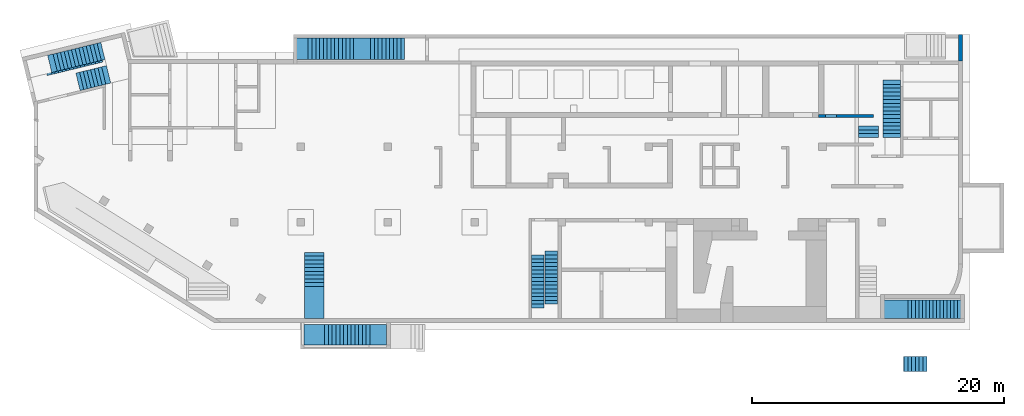
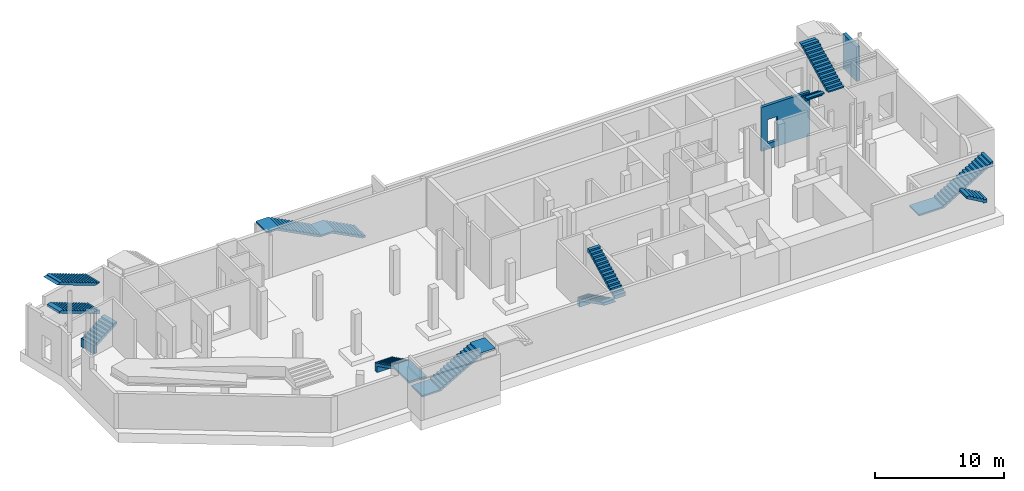
# One storey, part 4 of 9: 11 stairs, 2 walls, 2 openings.
"""IFC4 building model written with IfcOpenShell, lengths in millimetres."""

from ifc_helpers import new_model, entity, si_unit, converted_unit, derived_unit, direction, frame, origin, place, context, subcontext, project, spatial, indexed_curve, outline, extrude, polygons, material, type_object, element, save


model = new_model("IFC4")

# Units and contexts
model_context = context("Model", 3, precision=0.01, world=origin(), true_north=direction((6.12303176911189e-17, 1.0)))
plan_context = context("Plan", 3, precision=0.01, world=origin(), true_north=direction((6.12303176911189e-17, 1.0)))
body_context = subcontext(model_context, "Body", "Model", "MODEL_VIEW")
ifc_project = project(units=[si_unit("LENGTHUNIT", "METRE", prefix="MILLI"), si_unit("AREAUNIT", "SQUARE_METRE"), si_unit("VOLUMEUNIT", "CUBIC_METRE"), converted_unit("PLANEANGLEUNIT", "DEGREE", entity("IfcRatioMeasure", 0.0174532925199433), si_unit("PLANEANGLEUNIT", "RADIAN"), dimensions=[0, 0, 0, 0, 0, 0, 0]), si_unit("MASSUNIT", "GRAM", prefix="KILO"), derived_unit("MASSDENSITYUNIT", [(si_unit("MASSUNIT", "GRAM", prefix="KILO"), 1), (si_unit("LENGTHUNIT", "METRE"), -3)]), derived_unit("MOMENTOFINERTIAUNIT", [(si_unit("LENGTHUNIT", "METRE"), 4)]), si_unit("TIMEUNIT", "SECOND"), si_unit("FREQUENCYUNIT", "HERTZ"), si_unit("THERMODYNAMICTEMPERATUREUNIT", "DEGREE_CELSIUS"), derived_unit("THERMALTRANSMITTANCEUNIT", [(si_unit("MASSUNIT", "GRAM", prefix="KILO"), 1), (si_unit("THERMODYNAMICTEMPERATUREUNIT", "KELVIN"), -1), (si_unit("TIMEUNIT", "SECOND"), -3)]), derived_unit("VOLUMETRICFLOWRATEUNIT", [(si_unit("LENGTHUNIT", "METRE"), 3), (si_unit("TIMEUNIT", "SECOND"), -1)]), derived_unit("MASSFLOWRATEUNIT", [(si_unit("MASSUNIT", "GRAM", prefix="KILO"), 1), (si_unit("TIMEUNIT", "SECOND"), -1)]), derived_unit("ROTATIONALFREQUENCYUNIT", [(si_unit("TIMEUNIT", "SECOND"), -1)]), si_unit("ELECTRICCURRENTUNIT", "AMPERE"), si_unit("ELECTRICVOLTAGEUNIT", "VOLT"), si_unit("POWERUNIT", "WATT"), si_unit("FORCEUNIT", "NEWTON", prefix="KILO"), si_unit("ILLUMINANCEUNIT", "LUX"), si_unit("LUMINOUSFLUXUNIT", "LUMEN"), si_unit("LUMINOUSINTENSITYUNIT", "CANDELA"), derived_unit("USERDEFINED", [(si_unit("MASSUNIT", "GRAM", prefix="KILO"), -1), (si_unit("LENGTHUNIT", "METRE"), -2), (si_unit("TIMEUNIT", "SECOND"), 3), (si_unit("LUMINOUSFLUXUNIT", "LUMEN"), 1)]), derived_unit("LINEARVELOCITYUNIT", [(si_unit("LENGTHUNIT", "METRE"), 1), (si_unit("TIMEUNIT", "SECOND"), -1)]), si_unit("PRESSUREUNIT", "PASCAL"), derived_unit("USERDEFINED", [(si_unit("LENGTHUNIT", "METRE"), -2), (si_unit("MASSUNIT", "GRAM", prefix="KILO"), 1), (si_unit("TIMEUNIT", "SECOND"), -2)]), derived_unit("LINEARFORCEUNIT", [(si_unit("MASSUNIT", "GRAM", prefix="KILO"), 1), (si_unit("LENGTHUNIT", "METRE"), 1), (si_unit("TIMEUNIT", "SECOND"), -2), (si_unit("LENGTHUNIT", "METRE"), -1)]), derived_unit("PLANARFORCEUNIT", [(si_unit("MASSUNIT", "GRAM", prefix="KILO"), 1), (si_unit("LENGTHUNIT", "METRE"), 1), (si_unit("TIMEUNIT", "SECOND"), -2), (si_unit("LENGTHUNIT", "METRE"), -2)])], contexts=[model_context, plan_context])

# Site, building, storey
site_placement = place(None, origin())
site = spatial("IfcSite", under=ifc_project, at=site_placement, CompositionType="ELEMENT")
building_placement = place(site_placement, origin())
building = spatial("IfcBuilding", under=site, at=building_placement, CompositionType="ELEMENT")
storey_placement = place(building_placement, frame((0.0, 0.0, -4900.0)))
storey = spatial("IfcBuildingStorey", under=building, at=storey_placement, CompositionType="ELEMENT", Elevation=-4900.0)

# Wall, opening
ifc_material_1 = material()
wall_type_1 = type_object("IfcWallType", PredefinedType="STANDARD")
wall_1_placement = place(storey_placement, frame((73520.0002685547, 20499.999226356, 0.0), z_axis=(0.0, 0.0, 1.0), x_axis=(0.0, 1.0, 0.0)))
wall_1 = element("IfcWall", 1, at=wall_1_placement, inside=storey, type_object=wall_type_1, material=ifc_material_1, PredefinedType="NOTDEFINED", context=body_context, shape_type="Tessellation", body=[
    polygons([(0.0, -150.000000000004, 0.0), (2100.0, -149.999999999999, 0.0), (2100.0, -149.999999999999, 3300.0), (0.000426244457389657, -150.000000000004, 3300.0), (0.0, 149.999999999997, 0.0), (0.0, 149.999999999997, 3300.0), (1800.0, 150.000000000002, 3300.0), (2100.00042624446, 150.000000000002, 3300.0), (2100.0, 150.000000000002, 0.0), (1800.0, 150.000000000002, 0.0)], [[[1, 2, 3, 4]], [[5, 6, 7, 8, 9, 10]], [[2, 1, 5, 10, 9]], [[3, 2, 9, 8]], [[4, 3, 8, 7, 6]], [[1, 4, 6, 5]]], closed=True),
])
opening_1_placement = place(wall_1_placement, origin())
element("IfcOpeningElement", 2, at=opening_1_placement, cuts=wall_1, PredefinedType="OPENING", context=body_context, shape_type="SweptSolid", body=[
    extrude(outline(indexed_curve([(-1250.0, -1249.99999999902), (1250.0, -1249.99999999902), (1250.0, 1249.99999999902), (-1250.0, 1249.99999999902), (-1250.0, -1249.99999999902)], self_intersect=False)), frame((-11250.0, -250.0, 1950.0), z_axis=(0.0, 1.0, 0.0), x_axis=(1.0, 0.0, 0.0)), (0.0, 0.0, 1.0), 500.000000001948),
])

wall_type_2 = type_object("IfcWallType", PredefinedType="STANDARD")
wall_2_placement = place(storey_placement, frame((66630.0002685547, 16124.999226356, 0.0), z_axis=(0.0, 0.0, 1.0), x_axis=(-1.0, 0.0, 0.0)))
wall_2 = element("IfcWall", 3, at=wall_2_placement, inside=storey, type_object=wall_type_2, material=ifc_material_1, PredefinedType="NOTDEFINED", context=body_context, shape_type="Tessellation", body=[
    polygons([(3.67825270252959e-12, -125.0, 0.0), (3960.0, -125.0, 0.0), (4359.99999999999, -125.0, 0.0), (4359.99999999999, -125.0, 4170.0), (3960.0, -125.0, 4170.0), (1500.00000000001, -125.0, 4170.0), (1200.00000000001, -125.0, 4170.0), (3.67825270252959e-12, -125.0, 4170.0), (2929.99999999999, -125.0, 2829.99999999805), (3809.99999999998, -125.000000000002, 2829.99999999804), (3809.99999999998, -125.000000000002, 550.0), (2929.99999999999, -125.0, 550.0), (4359.99999999999, 125.000000000002, 0.0), (2.95528439311811e-12, 125.0, 0.0), (2.95528439311811e-12, 125.0, 4170.0), (1200.00000000001, 125.0, 4170.0), (1500.00000000001, 125.0, 4170.0), (3959.99999999999, 125.0, 4170.0), (4359.99999999999, 125.000000000002, 4170.0), (3809.99999999998, 125.0, 2829.99999999804), (2930.0, 125.0, 2829.99999999805), (2929.99999999999, 125.0, 550.0), (3809.99999999998, 125.0, 550.0)], [[[1, 2, 3, 4, 5, 6, 7, 8], [9, 10, 11, 12]], [[13, 14, 15, 16, 17, 18, 19], [20, 21, 22, 23]], [[3, 2, 1, 14, 13]], [[8, 7, 6, 5, 4, 19, 18, 17, 16, 15]], [[1, 8, 15, 14]], [[4, 3, 13, 19]], [[9, 21, 20, 10]], [[10, 20, 23, 11]], [[11, 23, 22, 12]], [[21, 9, 12, 22]]], closed=True),
])
opening_2_placement = place(wall_2_placement, frame((66630.0002685547, 16124.999226356, 0.0), z_axis=(0.0, 0.0, 1.0), x_axis=(-1.0, 0.0, 0.0)))
element("IfcOpeningElement", 4, at=opening_2_placement, cuts=wall_2, PredefinedType="OPENING", context=body_context, shape_type="SweptSolid", body=[
    extrude(outline(indexed_curve([(-439.999999999995, -1139.99999999902), (440.000000000004, -1139.99999999902), (440.000000000004, 1139.99999999902), (-439.999999999995, 1139.99999999902), (-439.999999999995, -1139.99999999902)], self_intersect=False)), frame((63260.0002685547, 16349.999226357, 1690.0), z_axis=(0.0, -1.0, 0.0), x_axis=(-1.0, 0.0, 0.0)), (0.0, 0.0, 1.0), 450.000000000965),
])

# Stairs
ifc_material_2 = material()
stair_type_1 = type_object("IfcStairType", PredefinedType="HALF_TURN_STAIR")
stair_1_placement = place(storey_placement, origin())
element("IfcStair", 5, at=stair_1_placement, inside=storey, type_object=stair_type_1, material=ifc_material_2, PredefinedType="HALF_TURN_STAIR", context=body_context, shape_type="SweptSolid", body=[
    extrude(outline(indexed_curve([(884.697440245459, -649.658737997728), (1284.69744024546, -649.658737997728), (1284.69744024546, -449.658737997728), (1231.91103574541, -449.658737997728), (674.14015934545, -170.773299797745), (-915.302559754544, 623.948059752256), (-915.302559754547, 1220.34126200228), (-1215.30255975455, 1220.34126200228), (-1215.30255975455, 400.341262002277), (-915.302559754545, 400.341262002276), (-915.302559754546, 250.341262002277), (-615.302559754544, 250.341262002276), (-615.302559754546, 100.341262002276), (-315.302559754542, 100.341262002275), (-315.302559754543, -49.6587379977246), (-15.3025597545405, -49.6587379977254), (-15.3025597545419, -199.658737997725), (284.69744024546, -199.658737997726), (284.697440245459, -349.658737997726), (584.697440245461, -349.658737997727), (584.69744024546, -499.658737997727), (884.69744024546, -499.658737997728), (884.697440245459, -649.658737997728)], self_intersect=False)), frame((4851.81307444231, 18434.3022675347, 1220.34126200228), z_axis=(-0.236826092990336, 0.971552058141473, 0.0), x_axis=(0.971552058141473, 0.236826092990336, 0.0)), (0.0, 0.0, 1.0), 1419.99999999999),
])
stair_type_2 = type_object("IfcStairType", PredefinedType="HALF_TURN_STAIR")
stair_2_placement = place(storey_placement, origin())
element("IfcStair", 6, at=stair_2_placement, inside=storey, type_object=stair_type_2, material=ifc_material_2, PredefinedType="HALF_TURN_STAIR", context=body_context, shape_type="SweptSolid", body=[
    extrude(outline(indexed_curve([(907.575757575757, -2048.08978365272), (1257.57575757576, -2048.08978365272), (1257.57575757576, -2000.87618815276), (-842.424242424243, 2199.12381184728), (-842.424242424243, 2298.17805111697), (-1042.42424242424, 2298.17805111697), (-1042.42424242424, 1851.91021634732), (-892.424242424243, 1851.91021634732), (-892.424242424243, 1551.91021634731), (-742.424242424243, 1551.91021634731), (-742.424242424243, 1251.91021634731), (-592.424242424243, 1251.91021634731), (-592.424242424243, 951.910216347304), (-442.424242424243, 951.910216347304), (-442.424242424243, 651.910216347299), (-292.424242424243, 651.910216347299), (-292.424242424243, 351.910216347297), (-142.424242424243, 351.910216347297), (-142.424242424243, 51.9102163472945), (7.57575757575671, 51.9102163472945), (7.57575757575671, -248.08978365271), (157.575757575757, -248.08978365271), (157.575757575757, -548.089783652713), (307.575757575757, -548.089783652713), (307.575757575757, -848.089783652714), (457.575757575757, -848.089783652714), (457.575757575757, -1148.08978365272), (607.575757575757, -1148.08978365272), (607.575757575757, -1448.08978365272), (757.575757575757, -1448.08978365272), (757.575757575757, -1748.08978365272), (907.575757575757, -1748.08978365272), (907.575757575757, -2048.08978365272)], self_intersect=False)), frame((3655.43157349411, 20118.8909930584, 2927.57575757576), z_axis=(-0.236826092990328, 0.971552058141475, 0.0), x_axis=(0.0, 0.0, -1.0)), (0.0, 0.0, 1.0), 1400.0),
])
stair_type_3 = type_object("IfcStairType", PredefinedType="HALF_TURN_STAIR")
stair_3_placement = place(storey_placement, origin())
element("IfcStair", 7, at=stair_3_placement, inside=storey, type_object=stair_type_3, material=ifc_material_2, PredefinedType="HALF_TURN_STAIR", context=body_context, shape_type="SweptSolid", body=[
    extrude(outline(indexed_curve([(982.941176470589, -2214.83609385294), (1332.94117647059, -2214.83609385294), (1332.94117647059, -2167.62249835299), (-597.058823529415, 1692.37750164703), (-597.058823529415, 1960.16390614706), (-847.058823529415, 1960.16390614706), (-847.058823529415, 1985.16390614706), (-967.058823529411, 1985.16390614706), (-967.058823529411, 1685.16390614706), (-817.058823529411, 1685.16390614706), (-817.058823529411, 1385.16390614706), (-667.058823529411, 1385.16390614706), (-667.058823529411, 1085.16390614706), (-517.058823529411, 1085.16390614706), (-517.058823529411, 785.16390614706), (-367.058823529411, 785.163906147061), (-367.058823529411, 485.16390614706), (-217.058823529411, 485.16390614706), (-217.058823529411, 185.16390614706), (-67.0588235294113, 185.16390614706), (-67.0588235294114, -114.836093852941), (82.9411764705886, -114.836093852941), (82.9411764705886, -414.836093852941), (232.941176470589, -414.836093852941), (232.941176470589, -714.836093852942), (382.941176470589, -714.836093852942), (382.941176470589, -1014.83609385294), (532.941176470589, -1014.83609385294), (532.941176470589, -1314.83609385294), (682.941176470589, -1314.83609385294), (682.941176470589, -1614.83609385294), (832.941176470589, -1614.83609385294), (832.941176470589, -1914.83609385294), (982.941176470589, -1914.83609385294), (982.941176470589, -2214.83609385294)], self_intersect=False)), frame((40550.0002685547, 3414.83532020911, 3902.94117647059), z_axis=(1.0, 0.0, 0.0), x_axis=(0.0, 0.0, -1.0)), (0.0, 0.0, 1.0), 999.999999999998),
    extrude(outline(indexed_curve([(-1987.5, -836.337075140623), (-1987.5, -1656.33707514062), (-1687.5, -1656.33707514062), (-1687.5, -1059.9438728906), (2212.5, 890.056127109391), (2212.5, 913.662924859368), (1912.5, 913.662924859367), (1912.5, 963.66292485937), (1612.5, 963.662924859371), (1612.5, 813.662924859371), (1312.5, 813.662924859371), (1312.5, 663.662924859371), (1012.5, 663.662924859372), (1012.5, 513.662924859372), (712.500000000001, 513.662924859373), (712.5, 363.662924859372), (412.5, 363.662924859373), (412.5, 213.662924859373), (112.5, 213.662924859374), (112.499999999999, 63.6629248593734), (-187.500000000001, 63.6629248593739), (-187.500000000001, -86.3370751406256), (-487.500000000001, -86.337075140625), (-487.500000000001, -236.337075140626), (-787.500000000001, -236.337075140625), (-787.500000000001, -386.337075140625), (-1087.5, -386.337075140624), (-1087.5, -536.337075140625), (-1387.5, -536.337075140624), (-1387.5, -686.337075140623), (-1687.5, -686.337075140623), (-1687.5, -836.337075140623), (-1987.5, -836.337075140623)], self_intersect=False)), frame((39490.0002685546, 3112.49922635617, 1656.33707514063), z_axis=(-1.0, 0.0, 0.0), x_axis=(0.0, -1.0, 0.0)), (0.0, 0.0, -1.0), 999.999999999998),
])
stair_type_4 = type_object("IfcStairType", PredefinedType="HALF_TURN_STAIR")
stair_4_placement = place(storey_placement, origin())
element("IfcStair", 8, at=stair_4_placement, inside=storey, type_object=stair_type_4, material=ifc_material_2, PredefinedType="HALF_TURN_STAIR", context=body_context, shape_type="SweptSolid", body=[
    extrude(outline(indexed_curve([(1054.11145618, -792.544271909995), (3604.11145618, -792.544271909995), (3604.11145618, -592.544271909995), (1401.32505167996, -592.544271909995), (-1345.88854382, 781.062525839977), (-1345.88854382, 1377.45572808999), (-1645.88854382, 1377.45572808999), (-1645.88854382, 557.455728089999), (-1345.88854382, 557.455728089999), (-1345.88854382, 407.455728089999), (-1045.88854382, 407.45572809), (-1045.88854382, 257.45572809), (-745.888543819999, 257.45572809), (-745.888543819999, 107.45572809), (-445.888543819999, 107.455728090001), (-445.888543819999, -42.5442719099993), (-145.888543819999, -42.5442719099988), (-145.888543819999, -192.544271909999), (154.111456180001, -192.544271909998), (154.111456180001, -342.544271909998), (454.111456180001, -342.544271909998), (454.111456180001, -492.544271909998), (754.111456180001, -492.544271909997), (754.111456180001, -642.544271909997), (1054.11145618, -642.544271909997), (1054.11145618, -792.544271909995)], self_intersect=False)), frame((21470.0002685547, 3654.1106825363, 1377.45572809), z_axis=(1.0, 0.0, 0.0), x_axis=(0.0, -1.0, 0.0)), (0.0, 0.0, 1.0), 1550.0),
])
stair_type_5 = type_object("IfcStairType", PredefinedType="HALF_TURN_STAIR")
stair_5_placement = place(storey_placement, origin())
element("IfcStair", 9, at=stair_5_placement, inside=storey, type_object=stair_type_5, material=ifc_material_2, PredefinedType="HALF_TURN_STAIR", context=body_context, shape_type="SweptSolid", body=[
    extrude(outline(indexed_curve([(-1086.25, -1792.4716246135), (-916.250000000001, -1792.4716246135), (-916.250000000001, -1492.4716246135), (-746.25, -1492.4716246135), (-746.25, -1192.4716246135), (-576.25, -1192.4716246135), (-576.25, -892.471624613499), (-406.25, -892.471624613499), (-406.25, -592.471624613498), (-236.249999999999, -592.471624613498), (-236.249999999999, -292.471624613497), (-66.249999999999, -292.471624613497), (-66.249999999999, 7.52837538650388), (103.750000000001, 7.52837538650388), (103.750000000001, 307.528375386505), (273.750000000002, 307.528375386505), (273.750000000002, 607.528375386506), (443.750000000002, 607.528375386506), (443.750000000002, 907.528375386507), (613.750000000002, 907.528375386507), (613.750000000002, 1207.52837538651), (783.750000000003, 1207.52837538651), (783.750000000003, 1507.52837538651), (953.750000000003, 1507.52837538651), (953.750000000003, 1807.52837538651), (1123.75, 1807.52837538651), (1123.75, 3127.52837538649), (973.750000000003, 3127.52837538649), (973.75, 2147.07436920239), (-1236.25, -1752.92563079762), (-1236.25000000001, -3422.4716246135), (-1086.25000000001, -3422.4716246135), (-1086.25, -1792.4716246135)], self_intersect=False)), frame((24862.4718931681, -2050.00077364372, 3196.25), z_axis=(0.0, 1.0, 0.0), x_axis=(0.0, 0.0, 1.0)), (0.0, 0.0, 1.0), 1650.0),
])
stair_type_6 = type_object("IfcStairType", PredefinedType="HALF_TURN_STAIR")
stair_6_placement = place(storey_placement, origin())
element("IfcStair", 10, at=stair_6_placement, inside=storey, type_object=stair_type_6, material=ifc_material_2, PredefinedType="HALF_TURN_STAIR", context=body_context, shape_type="SweptSolid", body=[
    extrude(outline(indexed_curve([(-1327.89473684208, -1993.77245141249), (-1157.89473684208, -1993.77245141249), (-1157.89473684208, -1713.7724514125), (-987.894736842088, -1713.7724514125), (-987.894736842088, -1433.7724514125), (-817.89473684209, -1433.7724514125), (-817.89473684209, -1153.7724514125), (-647.894736842093, -1153.7724514125), (-647.894736842093, -873.772451412505), (-477.894736842096, -873.772451412505), (-477.894736842096, -593.772451412508), (-307.894736842099, -593.772451412508), (-307.894736842099, -313.772451412511), (-137.894736842102, -313.772451412511), (-137.894736842102, -33.7724514125137), (32.105263157895, -33.7724514125137), (32.105263157895, 246.227548587483), (202.105263157892, 246.227548587483), (202.105263157892, 526.22754858748), (372.105263157889, 526.22754858748), (372.105263157889, 806.227548587477), (542.105263157886, 806.227548587477), (542.105263157886, 1086.22754858747), (712.105263157884, 1086.22754858747), (712.105263157884, 1366.22754858747), (882.105263157881, 1366.22754858747), (882.105263157881, 1646.22754858747), (1052.10526315788, 1646.22754858747), (1052.10526315788, 1926.22754858747), (1222.10526315788, 1926.22754858747), (1222.10526315788, 2206.22754858746), (1392.10526315787, 2206.22754858746), (1392.10526315787, 2461.22754858751), (932.105263157873, 2461.22754858751), (932.105263157871, 2017.6100077785), (-1477.89473684209, -1951.80175692734), (-1477.89473684209, -4193.77245141249), (-1327.89473684209, -4193.77245141249), (-1327.89473684208, -1993.77245141249)], self_intersect=False)), frame((71363.7727199671, 49.9992263559642, 3297.89473684208), z_axis=(0.0, 1.0, 0.0), x_axis=(0.0, 0.0, 1.0)), (0.0, 0.0, 1.0), 1495.00000000001),
])
stair_type_7 = type_object("IfcStairType", PredefinedType="HALF_TURN_STAIR")
stair_7_placement = place(storey_placement, origin())
element("IfcStair", 11, at=stair_7_placement, inside=storey, type_object=stair_type_7, material=ifc_material_2, PredefinedType="HALF_TURN_STAIR", context=body_context, shape_type="SweptSolid", body=[
    extrude(outline(indexed_curve([(-1736.15384615384, -3570.97946302001), (-1736.15384615384, -4750.97946302001), (-1586.15384615384, -4750.97946302001), (-1586.15384615384, -3907.43999214716), (428.846153846153, -7.4399921471611), (428.84615384615, 1042.56000785285), (1873.84615384615, 3839.33420140125), (1873.84615384615, 4079.02053698002), (1673.84615384615, 4079.02053698002), (1673.84615384615, 3779.02053698002), (1518.84615384615, 3779.02053698002), (1518.84615384615, 3479.02053698001), (1363.84615384615, 3479.02053698001), (1363.84615384615, 3179.02053698001), (1208.84615384615, 3179.02053698001), (1208.84615384615, 2879.02053698001), (1053.84615384615, 2879.02053698001), (1053.84615384615, 2579.02053698001), (898.846153846149, 2579.02053698001), (898.846153846149, 2279.02053698001), (743.846153846149, 2279.02053698001), (743.846153846149, 1979.02053698001), (588.846153846149, 1979.02053698001), (588.846153846149, 1679.02053698001), (433.846153846149, 1679.02053698001), (433.846153846149, 1379.02053698001), (278.846153846149, 1379.02053698001), (278.846153846153, 29.0205369800062), (123.846153846159, 29.0205369800062), (123.846153846159, -270.979463019995), (-31.1538461538414, -270.979463019995), (-31.1538461538414, -570.979463019996), (-186.153846153841, -570.979463019996), (-186.153846153841, -870.979463019997), (-341.153846153841, -870.979463019997), (-341.153846153841, -1170.97946302), (-496.153846153841, -1170.97946302), (-496.153846153841, -1470.97946302), (-651.153846153841, -1470.97946302), (-651.153846153841, -1770.97946302), (-806.153846153841, -1770.97946302), (-806.153846153841, -2070.97946302), (-961.153846153841, -2070.97946302), (-961.153846153841, -2370.97946302), (-1116.15384615384, -2370.97946302), (-1116.15384615384, -2670.97946302), (-1271.15384615384, -2670.97946302), (-1271.15384615384, -2970.97946302), (-1426.15384615384, -2970.97946302), (-1426.15384615384, -3270.97946302001), (-1581.15384615384, -3270.97946302001), (-1581.15384615384, -3570.97946302001), (-1736.15384615384, -3570.97946302001)], self_intersect=False)), frame((25340.9797315747, 20599.9992263561, 2448.84615384616), z_axis=(0.0, -1.0, 0.0), x_axis=(0.0, 0.0, -1.0)), (0.0, 0.0, -1.0), 1699.99999999999),
])
stair_type_8 = type_object("IfcStairType", PredefinedType="HALF_TURN_STAIR")
stair_8_placement = place(storey_placement, origin())
element("IfcStair", 12, at=stair_8_placement, inside=storey, type_object=stair_type_8, material=ifc_material_2, PredefinedType="HALF_TURN_STAIR", context=body_context, shape_type="SweptSolid", body=[
    extrude(outline(indexed_curve([(-784.999999999995, -150.000000000002), (784.999999999995, -150.000000000002), (784.999999999995, 149.999999999999), (-784.999999999995, 149.999999999999), (-784.999999999995, -150.000000000002)], self_intersect=False)), frame((66215.0002685547, 14579.999226356, 4750.0), z_axis=(0.0, 0.0, 1.0), x_axis=(-1.0, 0.0, 0.0)), (0.0, 0.0, 1.0), 120.000000000003),
    extrude(outline(indexed_curve([(-150.000000000001, -299.999999999999), (-6.76791955811495e-13, -299.999999999999), (2.70716782324598e-13, 0.0), (150.0, 0.0), (150.000000000001, 300.000000000001), (-150.000000000001, 300.000000000001), (-150.000000000001, -299.999999999999)], self_intersect=False)), frame((65430.0002685546, 15029.999226356, 4570.0), z_axis=(1.0, 0.0, 0.0), x_axis=(0.0, 0.0, 1.0)), (0.0, 0.0, 1.0), 1570.00000000001),
])
stair_type_9 = type_object("IfcStairType", PredefinedType="HALF_TURN_STAIR")
stair_9_placement = place(storey_placement, origin())
element("IfcStair", 13, at=stair_9_placement, inside=storey, type_object=stair_type_9, material=ifc_material_2, PredefinedType="HALF_TURN_STAIR", context=body_context, shape_type="SweptSolid", body=[
    extrude(outline(indexed_curve([(897.124385988235, -2015.78400925296), (1017.12438598824, -2015.78400925296), (1017.12438598824, -1715.78400925295), (1076.00982418822, -1715.78400925295), (1076.00982418822, -1626.34129015296), (-1002.87561401176, 2531.42958624701), (-1002.87561401176, 2184.21599074706), (-1052.87561401176, 2184.21599074706), (-1052.87561401176, 1884.21599074706), (-902.875614011764, 1884.21599074706), (-902.875614011764, 1584.21599074706), (-752.875614011764, 1584.21599074706), (-752.875614011764, 1284.21599074706), (-602.875614011764, 1284.21599074706), (-602.875614011764, 984.215990747055), (-452.875614011764, 984.215990747055), (-452.875614011764, 684.215990747054), (-302.875614011764, 684.215990747054), (-302.875614011764, 384.215990747053), (-152.875614011764, 384.215990747053), (-152.875614011764, 84.2159907470516), (-2.8756140117639, 84.2159907470516), (-2.8756140117639, -215.784009252949), (147.124385988236, -215.784009252949), (147.124385988236, -515.784009252951), (297.124385988236, -515.784009252951), (297.124385988236, -815.784009252952), (447.124385988236, -815.784009252952), (447.124385988236, -1115.78400925295), (597.124385988236, -1115.78400925295), (597.124385988236, -1415.78400925295), (747.124385988236, -1415.78400925295), (747.124385988236, -1715.78400925296), (897.124385988236, -1715.78400925296), (897.124385988235, -2015.78400925296)], self_intersect=False)), frame((67360.0002685546, 16445.7832356089, 5767.12438598824), z_axis=(1.0, 0.0, 0.0), x_axis=(0.0, 0.0, -1.0)), (0.0, 0.0, 1.0), 1390.0),
])
stair_type_10 = type_object("IfcStairType", PredefinedType="HALF_TURN_STAIR")
stair_10_placement = place(storey_placement, origin())
element("IfcStair", 14, at=stair_10_placement, inside=storey, type_object=stair_type_10, material=ifc_material_2, PredefinedType="HALF_TURN_STAIR", context=body_context, shape_type="SweptSolid", body=[
    extrude(outline(indexed_curve([(964.374999999993, -2126.70084971877), (1084.37499999999, -2126.70084971877), (1084.37499999999, -1619.48725421881), (-935.625000000008, 2420.51274578127), (-935.625000000009, 2073.29915028128), (-985.624999999992, 2073.29915028128), (-985.624999999993, 1773.29915028128), (-835.624999999993, 1773.29915028128), (-835.624999999994, 1473.29915028127), (-685.624999999993, 1473.29915028127), (-685.624999999994, 1173.29915028127), (-535.624999999994, 1173.29915028127), (-535.624999999995, 873.299150281263), (-385.624999999995, 873.299150281262), (-385.624999999996, 573.299150281258), (-235.624999999996, 573.299150281257), (-235.624999999997, 273.299150281254), (-85.6249999999973, 273.299150281252), (-85.6249999999983, -26.7008497187483), (64.3750000000013, -26.7008497187509), (64.3750000000004, -326.700849718753), (214.375, -326.700849718754), (214.374999999999, -626.700849718755), (364.374999999999, -626.700849718756), (364.374999999998, -926.700849718759), (514.374999999998, -926.70084971876), (514.374999999997, -1226.70084971876), (664.374999999996, -1226.70084971876), (664.374999999995, -1526.70084971877), (814.374999999995, -1526.70084971877), (814.374999999994, -1826.70084971877), (964.374999999994, -1826.70084971877), (964.374999999993, -2126.70084971877)], self_intersect=False)), frame((3414.18080501468, 19905.6914272769, 5834.37499999999), z_axis=(-0.236826092990336, 0.971552058141473, 0.0), x_axis=(0.0, 0.0, -1.0)), (0.0, 0.0, 1.0), 1550.00000000006),
])
stair_type_11 = type_object("IfcStairType", PredefinedType="HALF_TURN_STAIR")
stair_11_placement = place(storey_placement, origin())
element("IfcStair", 15, at=stair_11_placement, inside=storey, type_object=stair_type_11, material=ifc_material_2, PredefinedType="HALF_TURN_STAIR", context=body_context, shape_type="SweptSolid", body=[
    extrude(outline(indexed_curve([(-524.698776195736, -614.54541224973), (-524.698776195736, -914.545412249731), (-324.698776195737, -914.545412249731), (-324.698776195737, -967.273404004243), (555.18041913181, 585.454587750266), (645.301223804264, 585.454587750266), (645.301223804263, 885.454587750276), (325.301223804259, 885.454587750276), (325.30122380426, 585.454587750275), (155.30122380426, 585.454587750275), (155.301223804261, 285.454587750274), (-14.6987761957394, 285.454587750274), (-14.6987761957383, -14.5454122497275), (-184.698776195738, -14.5454122497275), (-184.698776195737, -314.545412249729), (-354.698776195737, -314.545412249729), (-354.698776195736, -614.54541224973), (-524.698776195736, -614.54541224973)], self_intersect=False)), frame((69959.6737859029, -4155.00080359938, 5065.30122380426), z_axis=(0.0, -1.0, 0.0), x_axis=(0.0, 0.0, -1.0)), (0.0, 0.0, -1.0), 1200.0),
])

save(model, "model.ifc")
